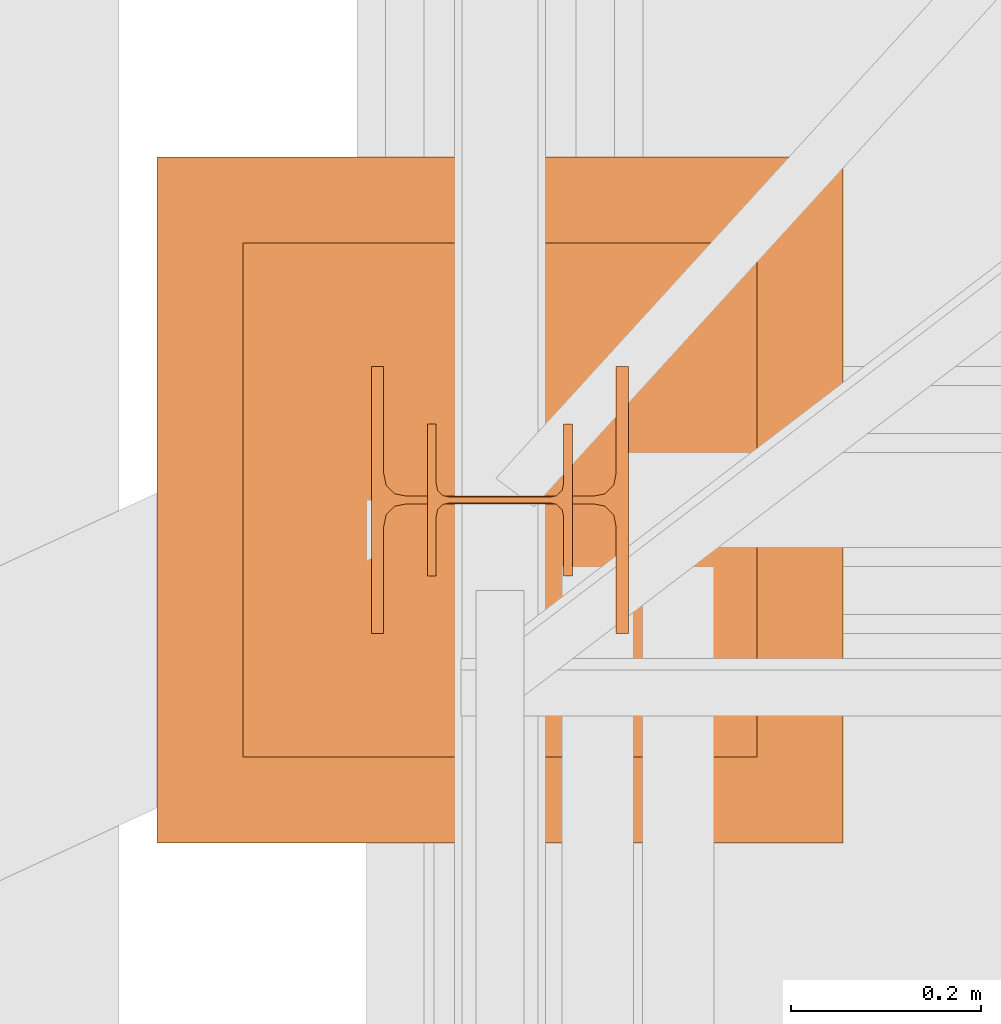
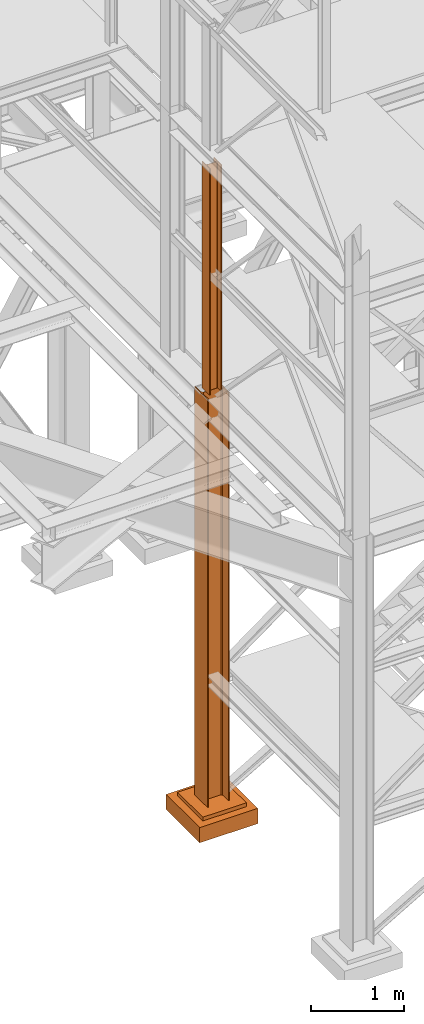
# One storey, part 13 of 208: 3 proxies.
"""IFC2X3 building model written with IfcOpenShell, lengths in millimetres."""

from ifc_helpers import new_model, entity, si_unit, converted_unit, frame, origin, origin_with_axes, place, context, subcontext, project, spatial, faceted_brep, element, save


model = new_model("IFC2X3")

# Units and contexts
model_context = context("Model", 3, precision=1e-05, world=origin())
plan_context = context("Plan", 3, precision=1e-05, world=origin())
body_context = subcontext(model_context, "Body", "Model", "MODEL_VIEW")
ifc_project = project(units=[si_unit("LENGTHUNIT", "METRE", prefix="MILLI"), converted_unit("PLANEANGLEUNIT", "DEGREE", entity("IfcPlaneAngleMeasure", 0.0174532925199433), si_unit("PLANEANGLEUNIT", "RADIAN"), dimensions=[0, 0, 0, 0, 0, 0, 0]), si_unit("AREAUNIT", "SQUARE_METRE"), si_unit("VOLUMEUNIT", "CUBIC_METRE")], contexts=[model_context, plan_context])

# Building, storey
building_placement = place(None, origin())
building = spatial("IfcBuilding", under=ifc_project, at=building_placement, CompositionType="COMPLEX")
storey_placement = place(building_placement, origin_with_axes())
storey = spatial("IfcBuildingStorey", under=building, at=storey_placement, Name="Geschoss", CompositionType="ELEMENT")

# Proxies
proxy_1_placement = place(storey_placement, frame((1063.164813417591, -22202.57439091394, -65.01000000000022), z_axis=(0.0, 0.0, 1.0), x_axis=(1.0, 0.0, 0.0)))
element("IfcBuildingElementProxy", 1, at=proxy_1_placement, inside=storey, context=body_context, shape_type="Brep", body=[
    faceted_brep([(0.009999999999990905, 0.01000000000203727, 5350.00999463558), (0.009999999999990905, 280.0100011920986, 5350.010005364416), (13.00999654293059, 280.0100011920986, 5350.010005364416), (13.00999654293059, 168.0100014603195, 5350.010005364416), (15.49606157302856, 155.5889206177053, 5350.010005364416), (24.58892149686812, 146.4960648848173, 5350.010005364416), (37.01000047683715, 144.0100007860419, 5350.010005364416), (233.010010251998, 144.0100007860419, 5350.010005364416), (245.431089231967, 146.4960648848173, 5350.010005364416), (254.5239491558066, 155.5889206177053, 5350.010005364416), (257.0100141859045, 168.0100014603195, 5350.010005364416), (257.0100141859045, 280.0100011920986, 5350.010005364416), (270.0100107288351, 280.0100011920986, 5350.010005364416), (270.0100107288351, 0.01000000000203727, 5350.00999463558), (257.0100141859045, 0.01000000000203727, 5350.00999463558), (257.0100141859045, 112.0099997317848, 5350.00999463558), (254.5239491558066, 124.431080574399, 5350.00999463558), (245.431089231967, 133.5239363072869, 5350.00999463558), (233.010010251998, 136.0100004060623, 5350.00999463558), (37.01000047683715, 136.0100004060623, 5350.00999463558), (24.58892149686812, 133.5239363072869, 5350.00999463558), (15.49606157302856, 124.431080574399, 5350.00999463558), (13.00999654293059, 112.0099997317848, 5350.00999463558), (13.00999654293059, 0.01000000000203727, 5350.00999463558), (0.009999999999990905, 280.0100011920986, 5350.010005364416), (0.009999999999990905, 0.01000000000203727, 5350.00999463558), (0.009999999999990905, 0.01000000000203727, 0.01000000000021828), (0.009999999999990905, 280.0100011920986, 0.01000000000021828), (0.009999999999990905, 280.0100011920986, 5350.010005364416), (0.009999999999990905, 280.0100011920986, 0.01000000000021828), (13.00999654293059, 280.0100011920986, 0.01000000000021828), (13.00999654293059, 280.0100011920986, 5350.010005364416), (13.00999654293059, 280.0100011920986, 5350.010005364416), (13.00999654293059, 280.0100011920986, 0.01000000000021828), (13.00999654293059, 168.0100014603195, 0.01000000000021828), (13.00999654293059, 168.0100014603195, 5350.010005364416), (13.00999654293059, 168.0100014603195, 5350.010005364416), (13.00999654293059, 168.0100014603195, 0.01000000000021828), (15.49606157302856, 155.5889206177053, 0.01000000000021828), (15.49606157302856, 155.5889206177053, 5350.010005364416), (15.49606157302856, 155.5889206177053, 5350.010005364416), (15.49606157302856, 155.5889206177053, 0.01000000000021828), (24.58892149686812, 146.4960648848173, 0.01000000000021828), (24.58892149686812, 146.4960648848173, 5350.010005364416), (24.58892149686812, 146.4960648848173, 5350.010005364416), (24.58892149686812, 146.4960648848173, 0.01000000000021828), (37.01000047683715, 144.0100007860419, 0.01000000000021828), (37.01000047683715, 144.0100007860419, 5350.010005364416), (37.01000047683715, 144.0100007860419, 5350.010005364416), (37.01000047683715, 144.0100007860419, 0.01000000000021828), (233.010010251998, 144.0100007860419, 0.01000000000021828), (233.010010251998, 144.0100007860419, 5350.010005364416), (233.010010251998, 144.0100007860419, 5350.010005364416), (233.010010251998, 144.0100007860419, 0.01000000000021828), (245.431089231967, 146.4960648848173, 0.01000000000021828), (245.431089231967, 146.4960648848173, 5350.010005364416), (245.431089231967, 146.4960648848173, 5350.010005364416), (245.431089231967, 146.4960648848173, 0.01000000000021828), (254.5239491558066, 155.5889206177053, 0.01000000000021828), (254.5239491558066, 155.5889206177053, 5350.010005364416), (254.5239491558066, 155.5889206177053, 5350.010005364416), (254.5239491558066, 155.5889206177053, 0.01000000000021828), (257.0100141859045, 168.0100014603195, 0.01000000000021828), (257.0100141859045, 168.0100014603195, 5350.010005364416), (257.0100141859045, 168.0100014603195, 5350.010005364416), (257.0100141859045, 168.0100014603195, 0.01000000000021828), (257.0100141859045, 280.0100011920986, 0.01000000000021828), (257.0100141859045, 280.0100011920986, 5350.010005364416), (257.0100141859045, 280.0100011920986, 5350.010005364416), (257.0100141859045, 280.0100011920986, 0.01000000000021828), (270.0100107288351, 280.0100011920986, 0.01000000000021828), (270.0100107288351, 280.0100011920986, 5350.010005364416), (270.0100107288351, 0.01000000000203727, 5350.00999463558), (270.0100107288351, 280.0100011920986, 5350.010005364416), (270.0100107288351, 280.0100011920986, 0.01000000000021828), (270.0100107288351, 0.01000000000203727, 0.01000000000021828), (257.0100141859045, 0.01000000000203727, 5350.00999463558), (270.0100107288351, 0.01000000000203727, 5350.00999463558), (270.0100107288351, 0.01000000000203727, 0.01000000000021828), (257.0100141859045, 0.01000000000203727, 0.01000000000021828), (257.0100141859045, 112.0099997317848, 5350.00999463558), (257.0100141859045, 0.01000000000203727, 5350.00999463558), (257.0100141859045, 0.01000000000203727, 0.01000000000021828), (257.0100141859045, 112.0099997317848, 0.01000000000021828), (254.5239491558066, 124.431080574399, 5350.00999463558), (257.0100141859045, 112.0099997317848, 5350.00999463558), (257.0100141859045, 112.0099997317848, 0.01000000000021828), (254.5239491558066, 124.431080574399, 0.01000000000021828), (245.431089231967, 133.5239363072869, 5350.00999463558), (254.5239491558066, 124.431080574399, 5350.00999463558), (254.5239491558066, 124.431080574399, 0.01000000000021828), (245.431089231967, 133.5239363072869, 0.01000000000021828), (233.010010251998, 136.0100004060623, 5350.00999463558), (245.431089231967, 133.5239363072869, 5350.00999463558), (245.431089231967, 133.5239363072869, 0.01000000000021828), (233.010010251998, 136.0100004060623, 0.01000000000021828), (37.01000047683715, 136.0100004060623, 5350.00999463558), (233.010010251998, 136.0100004060623, 5350.00999463558), (233.010010251998, 136.0100004060623, 0.01000000000021828), (37.01000047683715, 136.0100004060623, 0.01000000000021828), (24.58892149686812, 133.5239363072869, 5350.00999463558), (37.01000047683715, 136.0100004060623, 5350.00999463558), (37.01000047683715, 136.0100004060623, 0.01000000000021828), (24.58892149686812, 133.5239363072869, 0.01000000000021828), (15.49606157302856, 124.431080574399, 5350.00999463558), (24.58892149686812, 133.5239363072869, 5350.00999463558), (24.58892149686812, 133.5239363072869, 0.01000000000021828), (15.49606157302856, 124.431080574399, 0.01000000000021828), (13.00999654293059, 112.0099997317848, 5350.00999463558), (15.49606157302856, 124.431080574399, 5350.00999463558), (15.49606157302856, 124.431080574399, 0.01000000000021828), (13.00999654293059, 112.0099997317848, 0.01000000000021828), (13.00999654293059, 0.01000000000203727, 5350.00999463558), (13.00999654293059, 112.0099997317848, 5350.00999463558), (13.00999654293059, 112.0099997317848, 0.01000000000021828), (13.00999654293059, 0.01000000000203727, 0.01000000000021828), (0.009999999999990905, 0.01000000000203727, 5350.00999463558), (13.00999654293059, 0.01000000000203727, 5350.00999463558), (13.00999654293059, 0.01000000000203727, 0.01000000000021828), (0.009999999999990905, 0.01000000000203727, 0.01000000000021828), (0.009999999999990905, 0.01000000000203727, 0.01000000000021828), (13.00999654293059, 0.01000000000203727, 0.01000000000021828), (13.00999654293059, 112.0099997317848, 0.01000000000021828), (15.49606157302856, 124.431080574399, 0.01000000000021828), (24.58892149686812, 133.5239363072869, 0.01000000000021828), (37.01000047683715, 136.0100004060623, 0.01000000000021828), (233.010010251998, 136.0100004060623, 0.01000000000021828), (245.431089231967, 133.5239363072869, 0.01000000000021828), (254.5239491558066, 124.431080574399, 0.01000000000021828), (257.0100141859045, 112.0099997317848, 0.01000000000021828), (257.0100141859045, 0.01000000000203727, 0.01000000000021828), (270.0100107288351, 0.01000000000203727, 0.01000000000021828), (270.0100107288351, 280.0100011920986, 0.01000000000021828), (257.0100141859045, 280.0100011920986, 0.01000000000021828), (257.0100141859045, 168.0100014603195, 0.01000000000021828), (254.5239491558066, 155.5889206177053, 0.01000000000021828), (245.431089231967, 146.4960648848173, 0.01000000000021828), (233.010010251998, 144.0100007860419, 0.01000000000021828), (37.01000047683715, 144.0100007860419, 0.01000000000021828), (24.58892149686812, 146.4960648848173, 0.01000000000021828), (15.49606157302856, 155.5889206177053, 0.01000000000021828), (13.00999654293059, 168.0100014603195, 0.01000000000021828), (13.00999654293059, 280.0100011920986, 0.01000000000021828), (0.009999999999990905, 280.0100011920986, 0.01000000000021828)], [[[0, 1, 2, 3, 4, 5, 6, 7, 8, 9, 10, 11, 12, 13, 14, 15, 16, 17, 18, 19, 20, 21, 22, 23]], [[24, 25, 26, 27]], [[28, 29, 30, 31]], [[32, 33, 34, 35]], [[36, 37, 38, 39]], [[40, 41, 42, 43]], [[44, 45, 46, 47]], [[48, 49, 50, 51]], [[52, 53, 54, 55]], [[56, 57, 58, 59]], [[60, 61, 62, 63]], [[64, 65, 66, 67]], [[68, 69, 70, 71]], [[72, 73, 74, 75]], [[76, 77, 78, 79]], [[80, 81, 82, 83]], [[84, 85, 86, 87]], [[88, 89, 90, 91]], [[92, 93, 94, 95]], [[96, 97, 98, 99]], [[100, 101, 102, 103]], [[104, 105, 106, 107]], [[108, 109, 110, 111]], [[112, 113, 114, 115]], [[116, 117, 118, 119]], [[120, 121, 122, 123, 124, 125, 126, 127, 128, 129, 130, 131, 132, 133, 134, 135, 136, 137, 138, 139, 140, 141, 142, 143]]], orient=[[False], [False], [False], [False], [False], [False], [False], [False], [False], [False], [False], [False], [False], [False], [False], [False], [False], [False], [False], [False], [False], [False], [False], [False], [False], [False]]),
])
proxy_2_placement = place(storey_placement, frame((838.254968528666, -22422.57439031788, -315.01), z_axis=(0.0, 0.0, 1.0), x_axis=(1.0, 0.0, 0.0)))
element("IfcBuildingElementProxy", 2, at=proxy_2_placement, inside=storey, context=body_context, shape_type="Brep", body=[
    faceted_brep([(630.01, 630.0099999999984, 250.01), (630.01, 90.0099999999984, 250.01), (90.00999999999999, 90.0099999999984, 250.01), (90.00999999999999, 630.0099999999984, 250.01), (630.01, 630.0099999999984, 200.01), (630.01, 90.0099999999984, 200.01), (630.01, 90.0099999999984, 250.01), (630.01, 630.0099999999984, 250.01), (90.00999999999999, 630.0099999999984, 200.01), (630.01, 630.0099999999984, 200.01), (630.01, 630.0099999999984, 250.01), (90.00999999999999, 630.0099999999984, 250.01), (90.00999999999999, 90.0099999999984, 200.01), (90.00999999999999, 630.0099999999984, 200.01), (90.00999999999999, 630.0099999999984, 250.01), (90.00999999999999, 90.0099999999984, 250.01), (630.01, 90.0099999999984, 200.01), (90.00999999999999, 90.0099999999984, 200.01), (90.00999999999999, 90.0099999999984, 250.01), (630.01, 90.0099999999984, 250.01), (720.01, 0.00999999999839929, 0.009999999999990905), (720.01, 720.0099999999984, 0.009999999999990905), (0.009999999999990905, 720.0099999999984, 0.009999999999990905), (0.009999999999990905, 0.00999999999839929, 0.009999999999990905), (720.01, 720.0099999999984, 200.01), (720.01, 0.00999999999839929, 200.01), (0.009999999999990905, 0.00999999999839929, 200.01), (0.009999999999990905, 720.0099999999984, 200.01), (90.00999999999999, 90.0099999999984, 200.01), (630.01, 90.0099999999984, 200.01), (630.01, 630.0099999999984, 200.01), (90.00999999999999, 630.0099999999984, 200.01), (720.01, 720.0099999999984, 0.009999999999990905), (720.01, 0.00999999999839929, 0.009999999999990905), (720.01, 0.00999999999839929, 200.01), (720.01, 720.0099999999984, 200.01), (0.009999999999990905, 720.0099999999984, 0.009999999999990905), (720.01, 720.0099999999984, 0.009999999999990905), (720.01, 720.0099999999984, 200.01), (0.009999999999990905, 720.0099999999984, 200.01), (0.009999999999990905, 0.00999999999839929, 0.009999999999990905), (0.009999999999990905, 720.0099999999984, 0.009999999999990905), (0.009999999999990905, 720.0099999999984, 200.01), (0.009999999999990905, 0.00999999999839929, 200.01), (720.01, 0.00999999999839929, 0.009999999999990905), (0.009999999999990905, 0.00999999999839929, 0.009999999999990905), (0.009999999999990905, 0.00999999999839929, 200.01), (720.01, 0.00999999999839929, 200.01)], [[[0, 1, 2, 3]], [[4, 5, 6, 7]], [[8, 9, 10, 11]], [[12, 13, 14, 15]], [[16, 17, 18, 19]], [[20, 21, 22, 23]], [[24, 25, 26, 27], [28, 29, 30, 31]], [[32, 33, 34, 35]], [[36, 37, 38, 39]], [[40, 41, 42, 43]], [[44, 45, 46, 47]]], orient=[[False], [False], [False], [False], [False], [False], [False, False], [False], [False], [False], [False]]),
])
proxy_3_placement = place(storey_placement, frame((1122.164811912571, -22142.57439598033, 5284.990005364414), z_axis=(0.0, 0.0, 1.0), x_axis=(1.0, 0.0, 0.0)))
element("IfcBuildingElementProxy", 3, at=proxy_3_placement, inside=storey, context=body_context, shape_type="Brep", body=[
    faceted_brep([(152.0100100135812, 0.00999999999839929, 0.01000000000021828), (152.0100100135812, 160.0100113248809, 0.01000000000021828), (143.0100066757211, 160.0100113248809, 0.01000000000021828), (143.0100066757211, 98.01000675022442, 0.01000000000021828), (141.456217894555, 90.24683052509863, 0.01000000000021828), (135.773183236123, 84.56379586666662, 0.01000000000021828), (128.010009804965, 83.01000568851669, 0.01000000000021828), (24.01000393390655, 83.01000568851669, 0.01000000000021828), (16.24682677745818, 84.56379586666662, 0.01000000000021828), (10.56379211902618, 90.24683052509863, 0.01000000000021828), (9.010003337860098, 98.01000675022442, 0.01000000000021828), (9.010003337860098, 160.0100113248809, 0.01000000000021828), (0.009999999999990905, 160.0100113248809, 0.01000000000021828), (0.009999999999990905, 0.00999999999839929, 0.01000000000021828), (9.010003337860098, 0.00999999999839929, 0.01000000000021828), (9.010003337860098, 62.01000457465489, 0.01000000000021828), (10.56379211902618, 69.77318079978068, 0.01000000000021828), (16.24682677745818, 75.45621545821268, 0.01000000000021828), (24.01000393390655, 77.01000563636262, 0.01000000000021828), (128.010009804965, 77.01000563636262, 0.01000000000021828), (135.773183236123, 75.45621545821268, 0.01000000000021828), (141.456217894555, 69.77318079978068, 0.01000000000021828), (143.0100066757211, 62.01000457465489, 0.01000000000021828), (143.0100066757211, 0.00999999999839929, 0.01000000000021828), (152.0100100135812, 160.0100113248809, 0.01000000000021828), (152.0100100135812, 0.00999999999839929, 0.01000000000021828), (152.0100100135803, 0.00999999999839929, 2970.009992549421), (152.0100100135794, 160.0100113248809, 2970.009992549421), (143.0100066757211, 160.0100113248809, 0.01000000000021828), (152.0100100135812, 160.0100113248809, 0.01000000000021828), (152.0100100135794, 160.0100113248809, 2970.009992549421), (143.0100066757202, 160.0100113248809, 2970.009992549421), (143.0100066757211, 98.01000675022442, 0.01000000000021828), (143.0100066757211, 160.0100113248809, 0.01000000000021828), (143.0100066757202, 160.0100113248809, 2970.009992549421), (143.0100066757202, 98.01000675022442, 2970.009992549421), (141.456217894555, 90.24683052509863, 0.01000000000021828), (143.0100066757211, 98.01000675022442, 0.01000000000021828), (143.0100066757202, 98.01000675022442, 2970.009992549421), (141.4562178945541, 90.24683052509863, 2970.009992549421), (135.773183236123, 84.56379586666662, 0.01000000000021828), (141.456217894555, 90.24683052509863, 0.01000000000021828), (141.4562178945541, 90.24683052509863, 2970.009992549421), (135.7731832361221, 84.56379586666662, 2970.009992549421), (128.010009804965, 83.01000568851669, 0.01000000000021828), (135.773183236123, 84.56379586666662, 0.01000000000021828), (135.7731832361221, 84.56379586666662, 2970.009992549421), (128.0100098049641, 83.01000568851669, 2970.009992549421), (24.01000393390655, 83.01000568851669, 0.01000000000021828), (128.010009804965, 83.01000568851669, 0.01000000000021828), (128.0100098049641, 83.01000568851669, 2970.009992549421), (24.01000393390655, 83.01000568851669, 2970.009992549421), (16.24682677745818, 84.56379586666662, 0.01000000000021828), (24.01000393390655, 83.01000568851669, 0.01000000000021828), (24.01000393390655, 83.01000568851669, 2970.009992549421), (16.24682677745818, 84.56379586666662, 2970.009992549421), (10.56379211902618, 90.24683052509863, 0.01000000000021828), (16.24682677745818, 84.56379586666662, 0.01000000000021828), (16.24682677745818, 84.56379586666662, 2970.009992549421), (10.56379211902618, 90.24683052509863, 2970.009992549421), (9.010003337860098, 98.01000675022442, 0.01000000000021828), (10.56379211902618, 90.24683052509863, 0.01000000000021828), (10.56379211902618, 90.24683052509863, 2970.009992549421), (9.010003337859189, 98.01000675022442, 2970.009992549421), (9.010003337860098, 160.0100113248809, 0.01000000000021828), (9.010003337860098, 98.01000675022442, 0.01000000000021828), (9.010003337859189, 98.01000675022442, 2970.009992549421), (9.010003337859189, 160.0100113248809, 2970.009992549421), (0.009999999999990905, 160.0100113248809, 0.01000000000021828), (9.010003337860098, 160.0100113248809, 0.01000000000021828), (9.010003337859189, 160.0100113248809, 2970.009992549421), (0.009999999999990905, 160.0100113248809, 2970.009992549421), (0.009999999999990905, 0.00999999999839929, 0.01000000000021828), (0.009999999999990905, 160.0100113248809, 0.01000000000021828), (0.009999999999990905, 160.0100113248809, 2970.009992549421), (0.009999999999990905, 0.00999999999839929, 2970.009992549421), (9.010003337860098, 0.00999999999839929, 0.01000000000021828), (0.009999999999990905, 0.00999999999839929, 0.01000000000021828), (0.009999999999990905, 0.00999999999839929, 2970.009992549421), (9.010003337859189, 0.00999999999839929, 2970.009992549421), (9.010003337860098, 62.01000457465489, 0.01000000000021828), (9.010003337860098, 0.00999999999839929, 0.01000000000021828), (9.010003337859189, 0.00999999999839929, 2970.009992549421), (9.010003337859189, 62.01000457465489, 2970.009992549421), (10.56379211902618, 69.77318079978068, 0.01000000000021828), (9.010003337860098, 62.01000457465489, 0.01000000000021828), (9.010003337859189, 62.01000457465489, 2970.009992549421), (10.56379211902618, 69.77318079978068, 2970.009992549421), (16.24682677745818, 75.45621545821268, 0.01000000000021828), (10.56379211902618, 69.77318079978068, 0.01000000000021828), (10.56379211902618, 69.77318079978068, 2970.009992549421), (16.24682677745818, 75.45621545821268, 2970.009992549421), (24.01000393390655, 77.01000563636262, 0.01000000000021828), (16.24682677745818, 75.45621545821268, 0.01000000000021828), (16.24682677745818, 75.45621545821268, 2970.009992549421), (24.01000393390655, 77.01000563636262, 2970.009992549421), (128.010009804965, 77.01000563636262, 0.01000000000021828), (24.01000393390655, 77.01000563636262, 0.01000000000021828), (24.01000393390655, 77.01000563636262, 2970.009992549421), (128.0100098049641, 77.01000563636262, 2970.009992549421), (135.773183236123, 75.45621545821268, 0.01000000000021828), (128.010009804965, 77.01000563636262, 0.01000000000021828), (128.0100098049641, 77.01000563636262, 2970.009992549421), (135.7731832361221, 75.45621545821268, 2970.009992549421), (141.456217894555, 69.77318079978068, 0.01000000000021828), (135.773183236123, 75.45621545821268, 0.01000000000021828), (135.7731832361221, 75.45621545821268, 2970.009992549421), (141.4562178945541, 69.77318079978068, 2970.009992549423), (143.0100066757211, 62.01000457465489, 0.01000000000021828), (141.456217894555, 69.77318079978068, 0.01000000000021828), (141.4562178945541, 69.77318079978068, 2970.009992549423), (143.0100066757202, 62.01000457465489, 2970.009992549421), (143.0100066757211, 0.00999999999839929, 0.01000000000021828), (143.0100066757211, 62.01000457465489, 0.01000000000021828), (143.0100066757202, 62.01000457465489, 2970.009992549421), (143.0100066757202, 0.00999999999839929, 2970.009992549421), (152.0100100135812, 0.00999999999839929, 0.01000000000021828), (143.0100066757211, 0.00999999999839929, 0.01000000000021828), (143.0100066757202, 0.00999999999839929, 2970.009992549421), (152.0100100135803, 0.00999999999839929, 2970.009992549421), (152.0100100135803, 0.00999999999839929, 2970.009992549421), (143.0100066757202, 0.00999999999839929, 2970.009992549421), (143.0100066757202, 62.01000457465489, 2970.009992549421), (141.4562178945541, 69.77318079978068, 2970.009992549423), (135.7731832361221, 75.45621545821268, 2970.009992549421), (128.0100098049641, 77.01000563636262, 2970.009992549421), (24.01000393390655, 77.01000563636262, 2970.009992549421), (16.24682677745818, 75.45621545821268, 2970.009992549421), (10.56379211902618, 69.77318079978068, 2970.009992549421), (9.010003337859189, 62.01000457465489, 2970.009992549421), (9.010003337859189, 0.00999999999839929, 2970.009992549421), (0.009999999999990905, 0.00999999999839929, 2970.009992549421), (0.009999999999990905, 160.0100113248809, 2970.009992549421), (9.010003337859189, 160.0100113248809, 2970.009992549421), (9.010003337859189, 98.01000675022442, 2970.009992549421), (10.56379211902618, 90.24683052509863, 2970.009992549421), (16.24682677745818, 84.56379586666662, 2970.009992549421), (24.01000393390655, 83.01000568851669, 2970.009992549421), (128.0100098049641, 83.01000568851669, 2970.009992549421), (135.7731832361221, 84.56379586666662, 2970.009992549421), (141.4562178945541, 90.24683052509863, 2970.009992549421), (143.0100066757202, 98.01000675022442, 2970.009992549421), (143.0100066757202, 160.0100113248809, 2970.009992549421), (152.0100100135794, 160.0100113248809, 2970.009992549421)], [[[0, 1, 2, 3, 4, 5, 6, 7, 8, 9, 10, 11, 12, 13, 14, 15, 16, 17, 18, 19, 20, 21, 22, 23]], [[24, 25, 26, 27]], [[28, 29, 30, 31]], [[32, 33, 34, 35]], [[36, 37, 38, 39]], [[40, 41, 42, 43]], [[44, 45, 46, 47]], [[48, 49, 50, 51]], [[52, 53, 54, 55]], [[56, 57, 58, 59]], [[60, 61, 62, 63]], [[64, 65, 66, 67]], [[68, 69, 70, 71]], [[72, 73, 74, 75]], [[76, 77, 78, 79]], [[80, 81, 82, 83]], [[84, 85, 86, 87]], [[88, 89, 90, 91]], [[92, 93, 94, 95]], [[96, 97, 98, 99]], [[100, 101, 102, 103]], [[104, 105, 106, 107]], [[108, 109, 110, 111]], [[112, 113, 114, 115]], [[116, 117, 118, 119]], [[120, 121, 122, 123, 124, 125, 126, 127, 128, 129, 130, 131, 132, 133, 134, 135, 136, 137, 138, 139, 140, 141, 142, 143]]], orient=[[False], [False], [False], [False], [False], [False], [False], [False], [False], [False], [False], [False], [False], [False], [False], [False], [False], [False], [False], [False], [False], [False], [False], [False], [False], [False]]),
])

save(model, "model.ifc")
